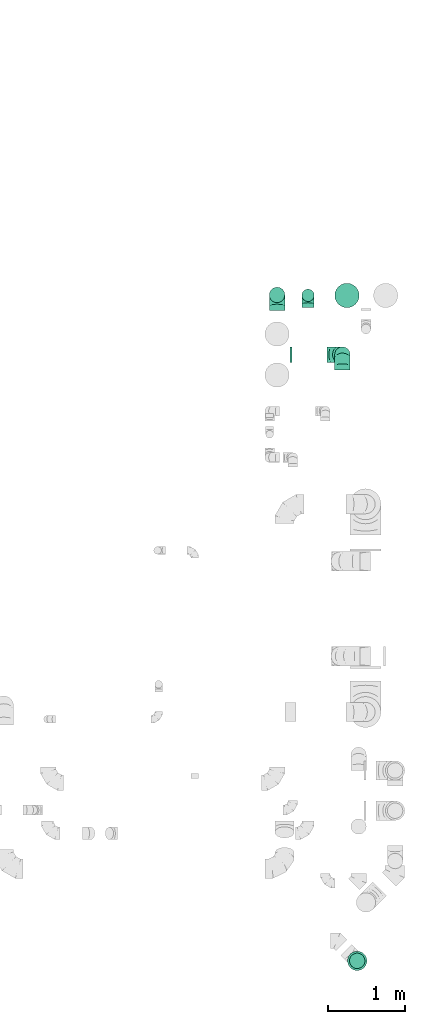
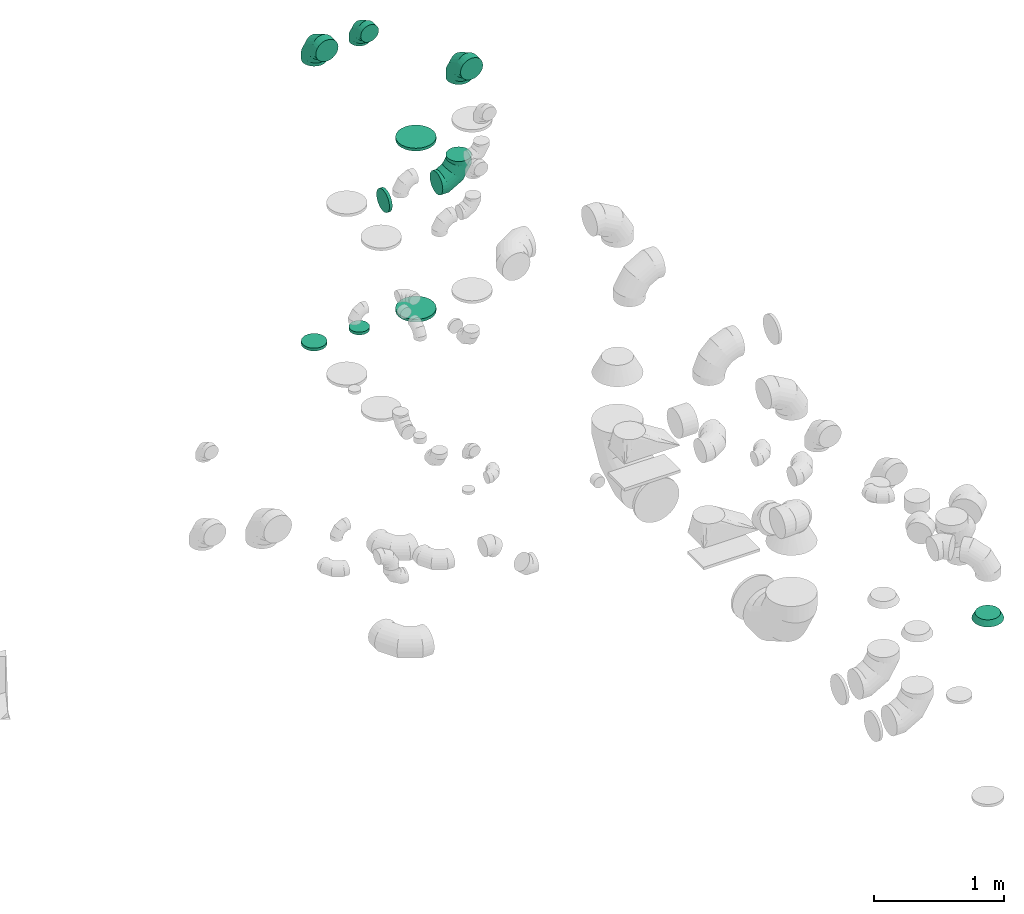
# One storey, part 46 of 59: 10 flow fittings.
"""IFC2X3 building model written with IfcOpenShell, lengths in millimetres."""

from ifc_helpers import new_model, entity, si_unit, converted_unit, derived_unit, direction, frame, origin, place, context, subcontext, project, spatial, faceted_brep, source, transform, mapped, material, type_object, type_shapes, element, save


model = new_model("IFC2X3")

# Units and contexts
model_context = context("Model", 3, precision=0.01, world=origin(), true_north=direction((6.12303176911189e-17, 1.0)))
body_context = subcontext(model_context, "Body", "Model", "MODEL_VIEW")
ifc_project = project(units=[si_unit("LENGTHUNIT", "METRE", prefix="MILLI"), si_unit("AREAUNIT", "SQUARE_METRE"), si_unit("VOLUMEUNIT", "CUBIC_METRE"), converted_unit("PLANEANGLEUNIT", "DEGREE", entity("IfcRatioMeasure", 0.0174532925199433), si_unit("PLANEANGLEUNIT", "RADIAN"), dimensions=[0, 0, 0, 0, 0, 0, 0]), si_unit("MASSUNIT", "GRAM", prefix="KILO"), derived_unit("MASSDENSITYUNIT", [(si_unit("MASSUNIT", "GRAM", prefix="KILO"), 1), (si_unit("LENGTHUNIT", "METRE"), -3)]), derived_unit("MOMENTOFINERTIAUNIT", [(si_unit("LENGTHUNIT", "METRE"), 4)]), si_unit("TIMEUNIT", "SECOND"), si_unit("FREQUENCYUNIT", "HERTZ"), si_unit("THERMODYNAMICTEMPERATUREUNIT", "DEGREE_CELSIUS"), derived_unit("THERMALTRANSMITTANCEUNIT", [(si_unit("MASSUNIT", "GRAM", prefix="KILO"), 1), (si_unit("THERMODYNAMICTEMPERATUREUNIT", "KELVIN"), -1), (si_unit("TIMEUNIT", "SECOND"), -3)]), derived_unit("VOLUMETRICFLOWRATEUNIT", [(si_unit("LENGTHUNIT", "METRE"), 3), (si_unit("TIMEUNIT", "SECOND"), -1)]), derived_unit("MASSFLOWRATEUNIT", [(si_unit("MASSUNIT", "GRAM", prefix="KILO"), 1), (si_unit("TIMEUNIT", "SECOND"), -1)]), derived_unit("ROTATIONALFREQUENCYUNIT", [(si_unit("TIMEUNIT", "SECOND"), -1)]), si_unit("ELECTRICCURRENTUNIT", "AMPERE"), si_unit("ELECTRICVOLTAGEUNIT", "VOLT"), si_unit("POWERUNIT", "WATT"), si_unit("FORCEUNIT", "NEWTON", prefix="KILO"), si_unit("ILLUMINANCEUNIT", "LUX"), si_unit("LUMINOUSFLUXUNIT", "LUMEN"), si_unit("LUMINOUSINTENSITYUNIT", "CANDELA"), derived_unit("USERDEFINED", [(si_unit("MASSUNIT", "GRAM", prefix="KILO"), -1), (si_unit("LENGTHUNIT", "METRE"), -2), (si_unit("TIMEUNIT", "SECOND"), 3), (si_unit("LUMINOUSFLUXUNIT", "LUMEN"), 1)]), derived_unit("LINEARVELOCITYUNIT", [(si_unit("LENGTHUNIT", "METRE"), 1), (si_unit("TIMEUNIT", "SECOND"), -1)]), si_unit("PRESSUREUNIT", "PASCAL"), derived_unit("USERDEFINED", [(si_unit("LENGTHUNIT", "METRE"), -2), (si_unit("MASSUNIT", "GRAM", prefix="KILO"), 1), (si_unit("TIMEUNIT", "SECOND"), -2)]), derived_unit("LINEARFORCEUNIT", [(si_unit("MASSUNIT", "GRAM", prefix="KILO"), 1), (si_unit("LENGTHUNIT", "METRE"), 1), (si_unit("TIMEUNIT", "SECOND"), -2), (si_unit("LENGTHUNIT", "METRE"), -1)]), derived_unit("PLANARFORCEUNIT", [(si_unit("MASSUNIT", "GRAM", prefix="KILO"), 1), (si_unit("LENGTHUNIT", "METRE"), 1), (si_unit("TIMEUNIT", "SECOND"), -2), (si_unit("LENGTHUNIT", "METRE"), -2)])], contexts=[model_context])

# Site, building, storey
site_placement = place(None, origin())
site = spatial("IfcSite", under=ifc_project, at=site_placement, CompositionType="ELEMENT")
building_placement = place(site_placement, origin())
building = spatial("IfcBuilding", under=site, at=building_placement, CompositionType="ELEMENT")
storey_placement = place(building_placement, frame((0.0, 0.0, 28200.0)))
storey = spatial("IfcBuildingStorey", under=building, at=storey_placement, CompositionType="ELEMENT", Elevation=28200.0)

# Flow fittings
ifc_material = material()
duct_fitting_type_1 = type_object("IfcDuctFittingType", PredefinedType="NOTDEFINED", material=ifc_material)
shared_shape_1 = source(origin(), body_context, "Body", "Brep", [
    faceted_brep([(-160.0, 0.0, -80.0), (-160.0, -20.71, -77.27), (-160.0, -40.0, -69.28), (-160.0, -56.57, -56.57), (-160.0, -69.28, -40.0), (-160.0, -77.27, -20.71), (-160.0, -80.0, 0.0), (-160.0, -77.27, 20.71), (-160.0, -69.28, 40.0), (-160.0, -56.57, 56.57), (-160.0, -40.0, 69.28), (-160.0, -20.71, 77.27), (-160.0, 0.0, 80.0), (-160.0, 20.71, 77.27), (-160.0, 40.0, 69.28), (-160.0, 56.57, 56.57), (-160.0, 69.28, 40.0), (-160.0, 77.27, 20.71), (-160.0, 80.0, 0.0), (-160.0, 77.27, -20.71), (-160.0, 69.28, -40.0), (-160.0, 56.57, -56.57), (-160.0, 40.0, -69.28), (-160.0, 20.71, -77.27), (-122.68, 20.71, 77.27), (-127.85, 40.0, 69.28), (-117.13, 0.0, 80.0), (-132.29, 56.57, 56.57), (-137.83, 77.27, 20.71), (-138.56, 80.0, 0.0), (-135.69, 69.28, 40.0), (-135.69, 69.28, -40.0), (-132.29, 56.57, -56.57), (-137.83, 77.27, -20.71), (-122.68, 20.71, -77.27), (-117.13, 0.0, -80.0), (-127.85, 40.0, -69.28), (-111.58, -20.71, -77.27), (-106.41, -40.0, -69.28), (-101.97, -56.57, -56.57), (-98.56, -69.28, -40.0), (-96.42, -77.27, -20.71), (-95.69, -80.0, 0.0), (-96.42, -77.27, 20.71), (-98.56, -69.28, 40.0), (-101.97, -56.57, 56.57), (-106.41, -40.0, 69.28), (-111.58, -20.71, 77.27), (-58.03, 58.03, 77.27), (-72.15, 72.15, 69.28), (-42.87, 42.87, 80.0), (-84.28, 84.28, 56.57), (-93.59, 93.59, 40.0), (-99.44, 99.44, 20.71), (-101.44, 101.44, 0.0), (-99.44, 99.44, -20.71), (-93.59, 93.59, -40.0), (-84.28, 84.28, -56.57), (-58.03, 58.03, -77.27), (-42.87, 42.87, -80.0), (-72.15, 72.15, -69.28), (-27.71, 27.71, -77.27), (-13.59, 13.59, -69.28), (-1.46, 1.46, -56.57), (7.85, -7.85, -40.0), (13.7, -13.7, -20.71), (15.69, -15.69, 0.0), (13.7, -13.7, 20.71), (7.85, -7.85, 40.0), (-1.46, 1.46, 56.57), (-13.59, 13.59, 69.28), (-27.71, 27.71, 77.27), (-20.71, 122.68, 77.27), (-40.0, 127.85, 69.28), (0.0, 117.13, 80.0), (-56.57, 132.29, 56.57), (-69.28, 135.69, 40.0), (-77.27, 137.83, 20.71), (-80.0, 138.56, 0.0), (-77.27, 137.83, -20.71), (-69.28, 135.69, -40.0), (-56.57, 132.29, -56.57), (-20.71, 122.68, -77.27), (0.0, 117.13, -80.0), (-40.0, 127.85, -69.28), (20.71, 111.58, -77.27), (40.0, 106.41, -69.28), (56.57, 101.97, -56.57), (69.28, 98.56, -40.0), (77.27, 96.42, -20.71), (80.0, 95.69, 0.0), (77.27, 96.42, 20.71), (69.28, 98.56, 40.0), (56.57, 101.97, 56.57), (40.0, 106.41, 69.28), (20.71, 111.58, 77.27), (-20.71, 160.0, -77.27), (-40.0, 160.0, -69.28), (-56.57, 160.0, -56.57), (-69.28, 160.0, -40.0), (-77.27, 160.0, -20.71), (-80.0, 160.0, 0.0), (-77.27, 160.0, 20.71), (-69.28, 160.0, 40.0), (-56.57, 160.0, 56.57), (-40.0, 160.0, 69.28), (-20.71, 160.0, 77.27), (0.0, 160.0, 80.0), (20.71, 160.0, 77.27), (40.0, 160.0, 69.28), (56.57, 160.0, 56.57), (69.28, 160.0, 40.0), (77.27, 160.0, 20.71), (80.0, 160.0, 0.0), (77.27, 160.0, -20.71), (69.28, 160.0, -40.0), (56.57, 160.0, -56.57), (40.0, 160.0, -69.28), (20.71, 160.0, -77.27), (0.0, 160.0, -80.0)], [[[0, 1, 2, 3, 4, 5, 6, 7, 8, 9, 10, 11, 12, 13, 14, 15, 16, 17, 18, 19, 20, 21, 22, 23]], [[24, 25, 14, 13]], [[26, 24, 13, 12]], [[14, 25, 27, 15]], [[28, 29, 18, 17]], [[30, 28, 17, 16]], [[15, 27, 30, 16]], [[20, 31, 32, 21]], [[33, 31, 20, 19]], [[18, 29, 33, 19]], [[34, 35, 0, 23]], [[36, 34, 23, 22]], [[32, 36, 22, 21]], [[1, 0, 35, 37]], [[2, 1, 37, 38]], [[3, 2, 38, 39]], [[5, 4, 40, 41]], [[6, 5, 41, 42]], [[39, 40, 4, 3]], [[6, 42, 43, 7]], [[7, 43, 44, 8]], [[8, 44, 45, 9]], [[9, 45, 46, 10]], [[10, 46, 47, 11]], [[26, 12, 11, 47]], [[48, 49, 25, 24]], [[50, 48, 24, 26]], [[27, 25, 49, 51]], [[52, 53, 28, 30]], [[51, 52, 30, 27]], [[29, 28, 53, 54]], [[55, 56, 31, 33]], [[54, 55, 33, 29]], [[32, 31, 56, 57]], [[58, 59, 35, 34]], [[60, 58, 34, 36]], [[57, 60, 36, 32]], [[37, 35, 59, 61]], [[38, 37, 61, 62]], [[39, 38, 62, 63]], [[41, 40, 64, 65]], [[42, 41, 65, 66]], [[63, 64, 40, 39]], [[43, 42, 66, 67]], [[44, 43, 67, 68]], [[68, 69, 45, 44]], [[46, 45, 69, 70]], [[47, 46, 70, 71]], [[26, 47, 71, 50]], [[72, 73, 49, 48]], [[74, 72, 48, 50]], [[51, 49, 73, 75]], [[76, 77, 53, 52]], [[75, 76, 52, 51]], [[54, 53, 77, 78]], [[79, 80, 56, 55]], [[78, 79, 55, 54]], [[57, 56, 80, 81]], [[82, 83, 59, 58]], [[84, 82, 58, 60]], [[81, 84, 60, 57]], [[61, 59, 83, 85]], [[62, 61, 85, 86]], [[63, 62, 86, 87]], [[65, 64, 88, 89]], [[66, 65, 89, 90]], [[87, 88, 64, 63]], [[67, 66, 90, 91]], [[68, 67, 91, 92]], [[92, 93, 69, 68]], [[70, 69, 93, 94]], [[71, 70, 94, 95]], [[50, 71, 95, 74]], [[96, 97, 98, 99, 100, 101, 102, 103, 104, 105, 106, 107, 108, 109, 110, 111, 112, 113, 114, 115, 116, 117, 118, 119]], [[72, 74, 107, 106]], [[73, 72, 106, 105]], [[75, 73, 105, 104]], [[77, 76, 103, 102]], [[78, 77, 102, 101]], [[75, 104, 103, 76]], [[78, 101, 100, 79]], [[79, 100, 99, 80]], [[80, 99, 98, 81]], [[84, 97, 96, 82]], [[82, 96, 119, 83]], [[84, 81, 98, 97]], [[118, 117, 86, 85]], [[119, 118, 85, 83]], [[116, 87, 86, 117]], [[88, 115, 114, 89]], [[89, 114, 113, 90]], [[115, 88, 87, 116]], [[112, 111, 92, 91]], [[113, 112, 91, 90]], [[111, 110, 93, 92]], [[95, 94, 109, 108]], [[74, 95, 108, 107]], [[110, 109, 94, 93]]]),
])
type_shapes(duct_fitting_type_1, [shared_shape_1])
flow_fitting_1_placement = place(storey_placement, frame((71970.11, 16643.42, 3400.0), z_axis=(1.0, 0.0, 0.0), x_axis=(0.0, 0.0, 1.0)))
element("IfcFlowFitting", 1, at=flow_fitting_1_placement, inside=storey, type_object=duct_fitting_type_1, material=ifc_material, context=body_context, shape_type="MappedRepresentation", body=[
    mapped(shared_shape_1, transform((0.0, 0.0, 0.0), scale=1.0)),
])
duct_fitting_type_2 = type_object("IfcDuctFittingType", PredefinedType="NOTDEFINED", material=ifc_material)
shared_shape_2 = source(origin(), body_context, "Body", "Brep", [
    faceted_brep([(-200.0, 0.0, -100.0), (-200.0, -25.88, -96.59), (-200.0, -50.0, -86.6), (-200.0, -70.71, -70.71), (-200.0, -86.6, -50.0), (-200.0, -96.59, -25.88), (-200.0, -100.0, 0.0), (-200.0, -96.59, 25.88), (-200.0, -86.6, 50.0), (-200.0, -70.71, 70.71), (-200.0, -50.0, 86.6), (-200.0, -25.88, 96.59), (-200.0, 0.0, 100.0), (-200.0, 25.88, 96.59), (-200.0, 50.0, 86.6), (-200.0, 70.71, 70.71), (-200.0, 86.6, 50.0), (-200.0, 96.59, 25.88), (-200.0, 100.0, 0.0), (-200.0, 96.59, -25.88), (-200.0, 86.6, -50.0), (-200.0, 70.71, -70.71), (-200.0, 50.0, -86.6), (-200.0, 25.88, -96.59), (-153.35, 25.88, 96.59), (-159.81, 50.0, 86.6), (-146.41, 0.0, 100.0), (-165.36, 70.71, 70.71), (-172.29, 96.59, 25.88), (-173.21, 100.0, 0.0), (-169.62, 86.6, 50.0), (-169.62, 86.6, -50.0), (-165.36, 70.71, -70.71), (-172.29, 96.59, -25.88), (-153.35, 25.88, -96.59), (-146.41, 0.0, -100.0), (-159.81, 50.0, -86.6), (-139.48, -25.88, -96.59), (-133.01, -50.0, -86.6), (-127.46, -70.71, -70.71), (-123.21, -86.6, -50.0), (-120.53, -96.59, -25.88), (-119.62, -100.0, 0.0), (-120.53, -96.59, 25.88), (-123.21, -86.6, 50.0), (-127.46, -70.71, 70.71), (-133.01, -50.0, 86.6), (-139.48, -25.88, 96.59), (-72.54, 72.54, 96.59), (-90.19, 90.19, 86.6), (-53.59, 53.59, 100.0), (-105.35, 105.35, 70.71), (-116.99, 116.99, 50.0), (-124.3, 124.3, 25.88), (-126.79, 126.79, 0.0), (-124.3, 124.3, -25.88), (-116.99, 116.99, -50.0), (-105.35, 105.35, -70.71), (-72.54, 72.54, -96.59), (-53.59, 53.59, -100.0), (-90.19, 90.19, -86.6), (-34.64, 34.64, -96.59), (-16.99, 16.99, -86.6), (-1.83, 1.83, -70.71), (9.81, -9.81, -50.0), (17.12, -17.12, -25.88), (19.62, -19.62, 0.0), (17.12, -17.12, 25.88), (9.81, -9.81, 50.0), (-1.83, 1.83, 70.71), (-16.99, 16.99, 86.6), (-34.64, 34.64, 96.59), (-25.88, 153.35, 96.59), (-50.0, 159.81, 86.6), (0.0, 146.41, 100.0), (-70.71, 165.36, 70.71), (-86.6, 169.62, 50.0), (-96.59, 172.29, 25.88), (-100.0, 173.21, 0.0), (-96.59, 172.29, -25.88), (-86.6, 169.62, -50.0), (-70.71, 165.36, -70.71), (-25.88, 153.35, -96.59), (0.0, 146.41, -100.0), (-50.0, 159.81, -86.6), (25.88, 139.48, -96.59), (50.0, 133.01, -86.6), (70.71, 127.46, -70.71), (86.6, 123.21, -50.0), (96.59, 120.53, -25.88), (100.0, 119.62, 0.0), (96.59, 120.53, 25.88), (86.6, 123.21, 50.0), (70.71, 127.46, 70.71), (50.0, 133.01, 86.6), (25.88, 139.48, 96.59), (-25.88, 200.0, -96.59), (-50.0, 200.0, -86.6), (-70.71, 200.0, -70.71), (-86.6, 200.0, -50.0), (-96.59, 200.0, -25.88), (-100.0, 200.0, 0.0), (-96.59, 200.0, 25.88), (-86.6, 200.0, 50.0), (-70.71, 200.0, 70.71), (-50.0, 200.0, 86.6), (-25.88, 200.0, 96.59), (0.0, 200.0, 100.0), (25.88, 200.0, 96.59), (50.0, 200.0, 86.6), (70.71, 200.0, 70.71), (86.6, 200.0, 50.0), (96.59, 200.0, 25.88), (100.0, 200.0, 0.0), (96.59, 200.0, -25.88), (86.6, 200.0, -50.0), (70.71, 200.0, -70.71), (50.0, 200.0, -86.6), (25.88, 200.0, -96.59), (0.0, 200.0, -100.0)], [[[0, 1, 2, 3, 4, 5, 6, 7, 8, 9, 10, 11, 12, 13, 14, 15, 16, 17, 18, 19, 20, 21, 22, 23]], [[24, 25, 14, 13]], [[26, 24, 13, 12]], [[14, 25, 27, 15]], [[28, 29, 18, 17]], [[30, 28, 17, 16]], [[15, 27, 30, 16]], [[20, 31, 32, 21]], [[33, 31, 20, 19]], [[18, 29, 33, 19]], [[34, 35, 0, 23]], [[36, 34, 23, 22]], [[32, 36, 22, 21]], [[1, 0, 35, 37]], [[2, 1, 37, 38]], [[38, 39, 3, 2]], [[5, 4, 40, 41]], [[6, 5, 41, 42]], [[39, 40, 4, 3]], [[6, 42, 43, 7]], [[7, 43, 44, 8]], [[8, 44, 45, 9]], [[9, 45, 46, 10]], [[10, 46, 47, 11]], [[26, 12, 11, 47]], [[48, 49, 25, 24]], [[50, 48, 24, 26]], [[27, 25, 49, 51]], [[52, 53, 28, 30]], [[51, 52, 30, 27]], [[29, 28, 53, 54]], [[55, 56, 31, 33]], [[54, 55, 33, 29]], [[32, 31, 56, 57]], [[58, 59, 35, 34]], [[60, 58, 34, 36]], [[57, 60, 36, 32]], [[37, 35, 59, 61]], [[38, 37, 61, 62]], [[39, 38, 62, 63]], [[41, 40, 64, 65]], [[42, 41, 65, 66]], [[63, 64, 40, 39]], [[43, 42, 66, 67]], [[44, 43, 67, 68]], [[68, 69, 45, 44]], [[46, 45, 69, 70]], [[47, 46, 70, 71]], [[26, 47, 71, 50]], [[72, 73, 49, 48]], [[74, 72, 48, 50]], [[51, 49, 73, 75]], [[76, 77, 53, 52]], [[75, 76, 52, 51]], [[54, 53, 77, 78]], [[79, 80, 56, 55]], [[78, 79, 55, 54]], [[57, 56, 80, 81]], [[82, 83, 59, 58]], [[84, 82, 58, 60]], [[81, 84, 60, 57]], [[61, 59, 83, 85]], [[62, 61, 85, 86]], [[63, 62, 86, 87]], [[65, 64, 88, 89]], [[66, 65, 89, 90]], [[87, 88, 64, 63]], [[67, 66, 90, 91]], [[68, 67, 91, 92]], [[92, 93, 69, 68]], [[70, 69, 93, 94]], [[71, 70, 94, 95]], [[50, 71, 95, 74]], [[96, 97, 98, 99, 100, 101, 102, 103, 104, 105, 106, 107, 108, 109, 110, 111, 112, 113, 114, 115, 116, 117, 118, 119]], [[72, 74, 107, 106]], [[73, 72, 106, 105]], [[75, 73, 105, 104]], [[102, 101, 78, 77]], [[103, 102, 77, 76]], [[75, 104, 103, 76]], [[78, 101, 100, 79]], [[79, 100, 99, 80]], [[80, 99, 98, 81]], [[84, 97, 96, 82]], [[82, 96, 119, 83]], [[84, 81, 98, 97]], [[118, 117, 86, 85]], [[119, 118, 85, 83]], [[116, 87, 86, 117]], [[88, 115, 114, 89]], [[89, 114, 113, 90]], [[115, 88, 87, 116]], [[91, 90, 113, 112]], [[92, 91, 112, 111]], [[111, 110, 93, 92]], [[95, 94, 109, 108]], [[74, 95, 108, 107]], [[110, 109, 94, 93]]]),
])
type_shapes(duct_fitting_type_2, [shared_shape_2])
for number, where, z_axis, x_axis in (
    (2, (72413.8, 15877.75, 3400.0), (-1.0, 0.0, 0.0), (0.0, 1.0, 0.0)),
    (3, (71570.11, 16648.42, 3400.0), (1.0, 0.0, 0.0), (0.0, 0.0, 1.0)),
    (4, (72413.8, 15877.75, 2275.0), (0.0, 1.0, 0.0), (0.0, 0.0, -1.0)),
):
    element("IfcFlowFitting", number, at=place(storey_placement, frame(where, z_axis=z_axis, x_axis=x_axis)), inside=storey, type_object=duct_fitting_type_2, material=ifc_material, context=body_context, shape_type="MappedRepresentation", body=[
        mapped(shared_shape_2, transform((0.0, 0.0, 0.0), scale=1.0)),
    ])
duct_fitting_type_3 = type_object("IfcDuctFittingType", PredefinedType="NOTDEFINED", material=ifc_material)
shared_shape_3 = source(origin(), body_context, "Body", "Brep", [
    faceted_brep([(20.0, 20.71, -77.27), (20.0, 40.0, -69.28), (20.0, 56.57, -56.57), (20.0, 69.28, -40.0), (20.0, 77.27, -20.71), (20.0, 80.0, 0.0), (20.0, 77.27, 20.71), (20.0, 69.28, 40.0), (20.0, 56.57, 56.57), (20.0, 40.0, 69.28), (20.0, 20.71, 77.27), (20.0, 0.0, 80.0), (20.0, -20.71, 77.27), (20.0, -40.0, 69.28), (20.0, -56.57, 56.57), (20.0, -69.28, 40.0), (20.0, -77.27, 20.71), (20.0, -80.0, 0.0), (20.0, -77.27, -20.71), (20.0, -69.28, -40.0), (20.0, -56.57, -56.57), (20.0, -40.0, -69.28), (20.0, -20.71, -77.27), (20.0, 0.0, -80.0), (0.0, 0.0, 80.0), (0.0, 20.71, 77.27), (-6.1, 20.71, 77.27), (-6.1, 0.0, 80.0), (0.0, 40.0, 69.28), (-6.1, 40.0, 69.28), (0.0, 56.57, 56.57), (-6.1, 56.57, 56.57), (0.0, 69.28, 40.0), (0.0, 77.27, 20.71), (-6.1, 77.27, 20.71), (-6.1, 69.28, 40.0), (0.0, 80.0, 0.0), (-6.1, 80.0, 0.0), (0.0, 77.27, -20.71), (-6.1, 77.27, -20.71), (0.0, 69.28, -40.0), (-6.1, 69.28, -40.0), (0.0, 56.57, -56.57), (-6.1, 56.57, -56.57), (0.0, 40.0, -69.28), (0.0, 20.71, -77.27), (-6.1, 20.71, -77.27), (-6.1, 40.0, -69.28), (0.0, 0.0, -80.0), (-6.1, 0.0, -80.0), (0.0, -20.71, -77.27), (-6.1, -20.71, -77.27), (0.0, -40.0, -69.28), (-6.1, -40.0, -69.28), (0.0, -56.57, -56.57), (-6.1, -56.57, -56.57), (0.0, -69.28, -40.0), (0.0, -77.27, -20.71), (-6.1, -77.27, -20.71), (-6.1, -69.28, -40.0), (0.0, -80.0, 0.0), (-6.1, -80.0, 0.0), (0.0, -77.27, 20.71), (-6.1, -77.27, 20.71), (0.0, -69.28, 40.0), (-6.1, -69.28, 40.0), (0.0, -56.57, 56.57), (-6.1, -56.57, 56.57), (0.0, -40.0, 69.28), (0.0, -20.71, 77.27), (-6.1, -20.71, 77.27), (-6.1, -40.0, 69.28)], [[[0, 1, 2, 3, 4, 5, 6, 7, 8, 9, 10, 11, 12, 13, 14, 15, 16, 17, 18, 19, 20, 21, 22, 23]], [[24, 11, 10, 25, 26, 27]], [[25, 10, 9, 28, 29, 26]], [[28, 9, 8, 30, 31, 29]], [[32, 7, 6, 33, 34, 35]], [[33, 6, 5, 36, 37, 34]], [[30, 8, 7, 32, 35, 31]], [[36, 5, 4, 38, 39, 37]], [[38, 4, 3, 40, 41, 39]], [[40, 3, 2, 42, 43, 41]], [[44, 1, 0, 45, 46, 47]], [[45, 0, 23, 48, 49, 46]], [[42, 2, 1, 44, 47, 43]], [[48, 23, 22, 50, 51, 49]], [[50, 22, 21, 52, 53, 51]], [[52, 21, 20, 54, 55, 53]], [[56, 19, 18, 57, 58, 59]], [[57, 18, 17, 60, 61, 58]], [[54, 20, 19, 56, 59, 55]], [[60, 17, 16, 62, 63, 61]], [[62, 16, 15, 64, 65, 63]], [[64, 15, 14, 66, 67, 65]], [[68, 13, 12, 69, 70, 71]], [[69, 12, 11, 24, 27, 70]], [[66, 14, 13, 68, 71, 67]], [[49, 51, 53, 55, 59, 58, 61, 63, 65, 67, 71, 70, 27, 26, 29, 31, 35, 34, 37, 39, 41, 43, 47, 46]]]),
])
type_shapes(duct_fitting_type_3, [shared_shape_3])
flow_fitting_2_placement = place(storey_placement, frame((71970.11, 16643.42, 525.0), z_axis=(0.0, 1.0, 0.0), x_axis=(0.0, 0.0, 1.0)))
element("IfcFlowFitting", 5, at=flow_fitting_2_placement, inside=storey, type_object=duct_fitting_type_3, material=ifc_material, context=body_context, shape_type="MappedRepresentation", body=[
    mapped(shared_shape_3, transform((0.0, 0.0, 0.0), scale=1.0)),
])
duct_fitting_type_4 = type_object("IfcDuctFittingType", PredefinedType="NOTDEFINED", material=ifc_material)
shared_shape_4 = source(origin(), body_context, "Body", "Brep", [
    faceted_brep([(20.0, 0.0, -100.0), (20.0, 25.88, -96.59), (20.0, 50.0, -86.6), (20.0, 70.71, -70.71), (20.0, 86.6, -50.0), (20.0, 96.59, -25.88), (20.0, 100.0, 0.0), (20.0, 96.59, 25.88), (20.0, 86.6, 50.0), (20.0, 70.71, 70.71), (20.0, 50.0, 86.6), (20.0, 25.88, 96.59), (20.0, 0.0, 100.0), (20.0, -25.88, 96.59), (20.0, -50.0, 86.6), (20.0, -70.71, 70.71), (20.0, -86.6, 50.0), (20.0, -96.59, 25.88), (20.0, -100.0, 0.0), (20.0, -96.59, -25.88), (20.0, -86.6, -50.0), (20.0, -70.71, -70.71), (20.0, -50.0, -86.6), (20.0, -25.88, -96.59), (0.0, 0.0, 100.0), (-6.1, 0.0, 100.0), (-6.1, -25.88, 96.59), (0.0, -25.88, 96.59), (-6.1, -50.0, 86.6), (0.0, -50.0, 86.6), (0.0, -70.71, 70.71), (-6.1, -70.71, 70.71), (0.0, -86.6, 50.0), (-6.1, -86.6, 50.0), (-6.1, -96.59, 25.88), (0.0, -96.59, 25.88), (-6.1, -100.0, 0.0), (0.0, -100.0, 0.0), (-6.1, -96.59, -25.88), (0.0, -96.59, -25.88), (-6.1, -86.6, -50.0), (0.0, -86.6, -50.0), (0.0, -70.71, -70.71), (-6.1, -70.71, -70.71), (0.0, -50.0, -86.6), (-6.1, -50.0, -86.6), (-6.1, -25.88, -96.59), (0.0, -25.88, -96.59), (-6.1, 0.0, -100.0), (0.0, 0.0, -100.0), (-6.1, 25.88, -96.59), (0.0, 25.88, -96.59), (-6.1, 50.0, -86.6), (0.0, 50.0, -86.6), (0.0, 70.71, -70.71), (-6.1, 70.71, -70.71), (0.0, 86.6, -50.0), (-6.1, 86.6, -50.0), (-6.1, 96.59, -25.88), (0.0, 96.59, -25.88), (-6.1, 100.0, 0.0), (0.0, 100.0, 0.0), (-6.1, 96.59, 25.88), (0.0, 96.59, 25.88), (-6.1, 86.6, 50.0), (0.0, 86.6, 50.0), (0.0, 70.71, 70.71), (-6.1, 70.71, 70.71), (0.0, 50.0, 86.6), (-6.1, 50.0, 86.6), (-6.1, 25.88, 96.59), (0.0, 25.88, 96.59)], [[[0, 1, 2, 3, 4, 5, 6, 7, 8, 9, 10, 11, 12, 13, 14, 15, 16, 17, 18, 19, 20, 21, 22, 23]], [[13, 12, 24, 25, 26, 27]], [[14, 13, 27, 26, 28, 29]], [[30, 15, 14, 29, 28, 31]], [[17, 16, 32, 33, 34, 35]], [[18, 17, 35, 34, 36, 37]], [[32, 16, 15, 30, 31, 33]], [[19, 18, 37, 36, 38, 39]], [[20, 19, 39, 38, 40, 41]], [[42, 21, 20, 41, 40, 43]], [[23, 22, 44, 45, 46, 47]], [[0, 23, 47, 46, 48, 49]], [[44, 22, 21, 42, 43, 45]], [[1, 0, 49, 48, 50, 51]], [[2, 1, 51, 50, 52, 53]], [[54, 3, 2, 53, 52, 55]], [[5, 4, 56, 57, 58, 59]], [[6, 5, 59, 58, 60, 61]], [[56, 4, 3, 54, 55, 57]], [[7, 6, 61, 60, 62, 63]], [[8, 7, 63, 62, 64, 65]], [[66, 9, 8, 65, 64, 67]], [[11, 10, 68, 69, 70, 71]], [[12, 11, 71, 70, 25, 24]], [[68, 10, 9, 66, 67, 69]], [[46, 45, 43, 40, 38, 36, 34, 33, 31, 28, 26, 25, 70, 69, 67, 64, 62, 60, 58, 57, 55, 52, 50, 48]]]),
])
type_shapes(duct_fitting_type_4, [shared_shape_4])
for number, where, z_axis, x_axis in (
    (6, (71570.11, 16648.42, 525.0), (0.0, -1.0, 0.0), (0.0, 0.0, 1.0)),
    (7, (71745.11, 15877.75, 2275.0), (0.0, 0.0, -1.0), (1.0, 0.0, 0.0)),
):
    element("IfcFlowFitting", number, at=place(storey_placement, frame(where, z_axis=z_axis, x_axis=x_axis)), inside=storey, type_object=duct_fitting_type_4, material=ifc_material, context=body_context, shape_type="MappedRepresentation", body=[
        mapped(shared_shape_4, transform((0.0, 0.0, 0.0), scale=1.0)),
    ])
duct_fitting_type_5 = type_object("IfcDuctFittingType", PredefinedType="NOTDEFINED", material=ifc_material)
shared_shape_5 = source(origin(), body_context, "Body", "Brep", [
    faceted_brep([(50.0, -73.47, -101.13), (50.0, -38.63, -118.88), (50.0, 0.0, -125.0), (50.0, 38.63, -118.88), (50.0, 73.47, -101.13), (50.0, 101.13, -73.47), (50.0, 118.88, -38.63), (50.0, 125.0, 0.0), (50.0, 118.88, 38.63), (50.0, 101.13, 73.47), (50.0, 73.47, 101.13), (50.0, 38.63, 118.88), (50.0, 0.0, 125.0), (50.0, -38.63, 118.88), (50.0, -73.47, 101.13), (50.0, -101.13, 73.47), (50.0, -118.88, 38.63), (50.0, -125.0, 0.0), (50.0, -118.88, -38.63), (50.0, -101.13, -73.47), (0.0, 30.9, -95.11), (0.0, 0.0, -100.0), (0.0, -30.9, -95.11), (0.0, -58.78, -80.9), (0.0, -80.9, -58.78), (0.0, -95.11, -30.9), (0.0, -100.0, 0.0), (0.0, -95.11, 30.9), (0.0, -80.9, 58.78), (0.0, -58.78, 80.9), (0.0, -30.9, 95.11), (0.0, 0.0, 100.0), (0.0, 30.9, 95.11), (0.0, 58.78, 80.9), (0.0, 80.9, 58.78), (0.0, 95.11, 30.9), (0.0, 100.0, 0.0), (0.0, 95.11, -30.9), (0.0, 80.9, -58.78), (0.0, 58.78, -80.9)], [[[0, 1, 2, 3, 4, 5, 6, 7, 8, 9, 10, 11, 12, 13, 14, 15, 16, 17, 18, 19]], [[20, 21, 22, 23, 24, 25, 26, 27, 28, 29, 30, 31, 32, 33, 34, 35, 36, 37, 38, 39]], [[35, 34, 9, 8]], [[36, 35, 8, 7]], [[34, 33, 10, 9]], [[10, 33, 32, 11]], [[11, 32, 31, 12]], [[30, 29, 14, 13]], [[31, 30, 13, 12]], [[29, 28, 15, 14]], [[15, 28, 27, 16]], [[16, 27, 26, 17]], [[25, 24, 19, 18]], [[26, 25, 18, 17]], [[24, 23, 0, 19]], [[0, 23, 22, 1]], [[1, 22, 21, 2]], [[20, 39, 4, 3]], [[21, 20, 3, 2]], [[39, 38, 5, 4]], [[5, 38, 37, 6]], [[6, 37, 36, 7]]]),
])
type_shapes(duct_fitting_type_5, [shared_shape_5])
flow_fitting_3_placement = place(storey_placement, frame((72605.18, 8046.98, 2840.0), z_axis=(-0.707106781186564, -0.707106781186531, 0.0), x_axis=(0.0, 0.0, -1.0)))
element("IfcFlowFitting", 8, at=flow_fitting_3_placement, inside=storey, type_object=duct_fitting_type_5, material=ifc_material, context=body_context, shape_type="MappedRepresentation", body=[
    mapped(shared_shape_5, transform((0.0, 0.0, 0.0), scale=1.0)),
])
duct_fitting_type_6 = type_object("IfcDuctFittingType", PredefinedType="NOTDEFINED", material=ifc_material)
shared_shape_6 = source(origin(), body_context, "Body", "Brep", [
    faceted_brep([(20.0, 40.76, -152.13), (20.0, 78.75, -136.4), (20.0, 111.37, -111.37), (20.0, 136.4, -78.75), (20.0, 152.13, -40.76), (20.0, 157.5, 0.0), (20.0, 152.13, 40.76), (20.0, 136.4, 78.75), (20.0, 111.37, 111.37), (20.0, 78.75, 136.4), (20.0, 40.76, 152.13), (20.0, 0.0, 157.5), (20.0, -40.76, 152.13), (20.0, -78.75, 136.4), (20.0, -111.37, 111.37), (20.0, -136.4, 78.75), (20.0, -152.13, 40.76), (20.0, -157.5, 0.0), (20.0, -152.13, -40.76), (20.0, -136.4, -78.75), (20.0, -111.37, -111.37), (20.0, -78.75, -136.4), (20.0, -40.76, -152.13), (20.0, 0.0, -157.5), (0.0, 0.0, 157.5), (0.0, 40.76, 152.13), (-6.1, 40.76, 152.13), (-6.1, 0.0, 157.5), (0.0, 78.75, 136.4), (-6.1, 78.75, 136.4), (0.0, 111.37, 111.37), (-6.1, 111.37, 111.37), (0.0, 136.4, 78.75), (0.0, 152.13, 40.76), (-6.1, 152.13, 40.76), (-6.1, 136.4, 78.75), (0.0, 157.5, 0.0), (-6.1, 157.5, 0.0), (0.0, 152.13, -40.76), (-6.1, 152.13, -40.76), (0.0, 136.4, -78.75), (-6.1, 136.4, -78.75), (0.0, 111.37, -111.37), (-6.1, 111.37, -111.37), (0.0, 0.0, -157.5), (-6.1, 0.0, -157.5), (-6.1, 40.76, -152.13), (0.0, 40.76, -152.13), (-6.1, 78.75, -136.4), (0.0, 78.75, -136.4), (0.0, -40.76, -152.13), (-6.1, -40.76, -152.13), (0.0, -78.75, -136.4), (-6.1, -78.75, -136.4), (0.0, -111.37, -111.37), (-6.1, -111.37, -111.37), (0.0, -136.4, -78.75), (0.0, -152.13, -40.76), (-6.1, -152.13, -40.76), (-6.1, -136.4, -78.75), (0.0, -157.5, 0.0), (-6.1, -157.5, 0.0), (0.0, -152.13, 40.76), (-6.1, -152.13, 40.76), (0.0, -136.4, 78.75), (-6.1, -136.4, 78.75), (0.0, -111.37, 111.37), (-6.1, -111.37, 111.37), (0.0, -78.75, 136.4), (0.0, -40.76, 152.13), (-6.1, -40.76, 152.13), (-6.1, -78.75, 136.4)], [[[0, 1, 2, 3, 4, 5, 6, 7, 8, 9, 10, 11, 12, 13, 14, 15, 16, 17, 18, 19, 20, 21, 22, 23]], [[24, 11, 10, 25, 26, 27]], [[25, 10, 9, 28, 29, 26]], [[28, 9, 8, 30, 31, 29]], [[32, 7, 6, 33, 34, 35]], [[33, 6, 5, 36, 37, 34]], [[30, 8, 7, 32, 35, 31]], [[36, 5, 4, 38, 39, 37]], [[38, 4, 3, 40, 41, 39]], [[40, 3, 2, 42, 43, 41]], [[0, 23, 44, 45, 46, 47]], [[1, 0, 47, 46, 48, 49]], [[49, 48, 43, 42, 2, 1]], [[44, 23, 22, 50, 51, 45]], [[50, 22, 21, 52, 53, 51]], [[52, 21, 20, 54, 55, 53]], [[56, 19, 18, 57, 58, 59]], [[57, 18, 17, 60, 61, 58]], [[54, 20, 19, 56, 59, 55]], [[60, 17, 16, 62, 63, 61]], [[62, 16, 15, 64, 65, 63]], [[64, 15, 14, 66, 67, 65]], [[68, 13, 12, 69, 70, 71]], [[69, 12, 11, 24, 27, 70]], [[66, 14, 13, 68, 71, 67]], [[45, 51, 53, 55, 59, 58, 61, 63, 65, 67, 71, 70, 27, 26, 29, 31, 35, 34, 37, 39, 41, 43, 48, 46]]]),
])
type_shapes(duct_fitting_type_6, [shared_shape_6])
flow_fitting_4_placement = place(storey_placement, frame((72472.91, 16641.7, 525.0), z_axis=(0.0, 1.0, 0.0), x_axis=(0.0, 0.0, 1.0)))
element("IfcFlowFitting", 9, at=flow_fitting_4_placement, inside=storey, type_object=duct_fitting_type_6, material=ifc_material, context=body_context, shape_type="MappedRepresentation", body=[
    mapped(shared_shape_6, transform((0.0, 0.0, 0.0), scale=1.0)),
])
duct_fitting_type_7 = type_object("IfcDuctFittingType", PredefinedType="NOTDEFINED", material=ifc_material)
shared_shape_7 = source(origin(), body_context, "Body", "Brep", [
    faceted_brep([(20.0, 0.0, -157.5), (20.0, 40.76, -152.13), (20.0, 78.75, -136.4), (20.0, 111.37, -111.37), (20.0, 136.4, -78.75), (20.0, 152.13, -40.76), (20.0, 157.5, 0.0), (20.0, 152.13, 40.76), (20.0, 136.4, 78.75), (20.0, 111.37, 111.37), (20.0, 78.75, 136.4), (20.0, 40.76, 152.13), (20.0, 0.0, 157.5), (20.0, -40.76, 152.13), (20.0, -78.75, 136.4), (20.0, -111.37, 111.37), (20.0, -136.4, 78.75), (20.0, -152.13, 40.76), (20.0, -157.5, 0.0), (20.0, -152.13, -40.76), (20.0, -136.4, -78.75), (20.0, -111.37, -111.37), (20.0, -78.75, -136.4), (20.0, -40.76, -152.13), (0.0, 0.0, 157.5), (-6.1, 0.0, 157.5), (-6.1, -40.76, 152.13), (0.0, -40.76, 152.13), (-6.1, -78.75, 136.4), (0.0, -78.75, 136.4), (0.0, -111.37, 111.37), (-6.1, -111.37, 111.37), (0.0, -136.4, 78.75), (-6.1, -136.4, 78.75), (-6.1, -152.13, 40.76), (0.0, -152.13, 40.76), (-6.1, -157.5, 0.0), (0.0, -157.5, 0.0), (-6.1, -152.13, -40.76), (0.0, -152.13, -40.76), (-6.1, -136.4, -78.75), (0.0, -136.4, -78.75), (0.0, -111.37, -111.37), (-6.1, -111.37, -111.37), (0.0, 0.0, -157.5), (0.0, -40.76, -152.13), (-6.1, -40.76, -152.13), (-6.1, 0.0, -157.5), (0.0, -78.75, -136.4), (-6.1, -78.75, -136.4), (-6.1, 40.76, -152.13), (0.0, 40.76, -152.13), (-6.1, 78.75, -136.4), (0.0, 78.75, -136.4), (0.0, 111.37, -111.37), (-6.1, 111.37, -111.37), (0.0, 136.4, -78.75), (-6.1, 136.4, -78.75), (-6.1, 152.13, -40.76), (0.0, 152.13, -40.76), (-6.1, 157.5, 0.0), (0.0, 157.5, 0.0), (-6.1, 152.13, 40.76), (0.0, 152.13, 40.76), (-6.1, 136.4, 78.75), (0.0, 136.4, 78.75), (0.0, 111.37, 111.37), (-6.1, 111.37, 111.37), (0.0, 78.75, 136.4), (-6.1, 78.75, 136.4), (-6.1, 40.76, 152.13), (0.0, 40.76, 152.13)], [[[0, 1, 2, 3, 4, 5, 6, 7, 8, 9, 10, 11, 12, 13, 14, 15, 16, 17, 18, 19, 20, 21, 22, 23]], [[13, 12, 24, 25, 26, 27]], [[14, 13, 27, 26, 28, 29]], [[30, 15, 14, 29, 28, 31]], [[17, 16, 32, 33, 34, 35]], [[18, 17, 35, 34, 36, 37]], [[32, 16, 15, 30, 31, 33]], [[19, 18, 37, 36, 38, 39]], [[20, 19, 39, 38, 40, 41]], [[42, 21, 20, 41, 40, 43]], [[44, 0, 23, 45, 46, 47]], [[48, 49, 46, 45, 23, 22]], [[22, 21, 42, 43, 49, 48]], [[1, 0, 44, 47, 50, 51]], [[2, 1, 51, 50, 52, 53]], [[54, 3, 2, 53, 52, 55]], [[5, 4, 56, 57, 58, 59]], [[6, 5, 59, 58, 60, 61]], [[56, 4, 3, 54, 55, 57]], [[7, 6, 61, 60, 62, 63]], [[8, 7, 63, 62, 64, 65]], [[66, 9, 8, 65, 64, 67]], [[11, 10, 68, 69, 70, 71]], [[12, 11, 71, 70, 25, 24]], [[68, 10, 9, 66, 67, 69]], [[46, 49, 43, 40, 38, 36, 34, 33, 31, 28, 26, 25, 70, 69, 67, 64, 62, 60, 58, 57, 55, 52, 50, 47]]]),
])
type_shapes(duct_fitting_type_7, [shared_shape_7])
flow_fitting_5_placement = place(storey_placement, frame((72472.91, 16641.7, 2150.0), z_axis=(0.0, 1.0, 0.0), x_axis=(0.0, 0.0, -1.0)))
element("IfcFlowFitting", 10, at=flow_fitting_5_placement, inside=storey, type_object=duct_fitting_type_7, material=ifc_material, context=body_context, shape_type="MappedRepresentation", body=[
    mapped(shared_shape_7, transform((0.0, 0.0, 0.0), scale=1.0)),
])

save(model, "model.ifc")
